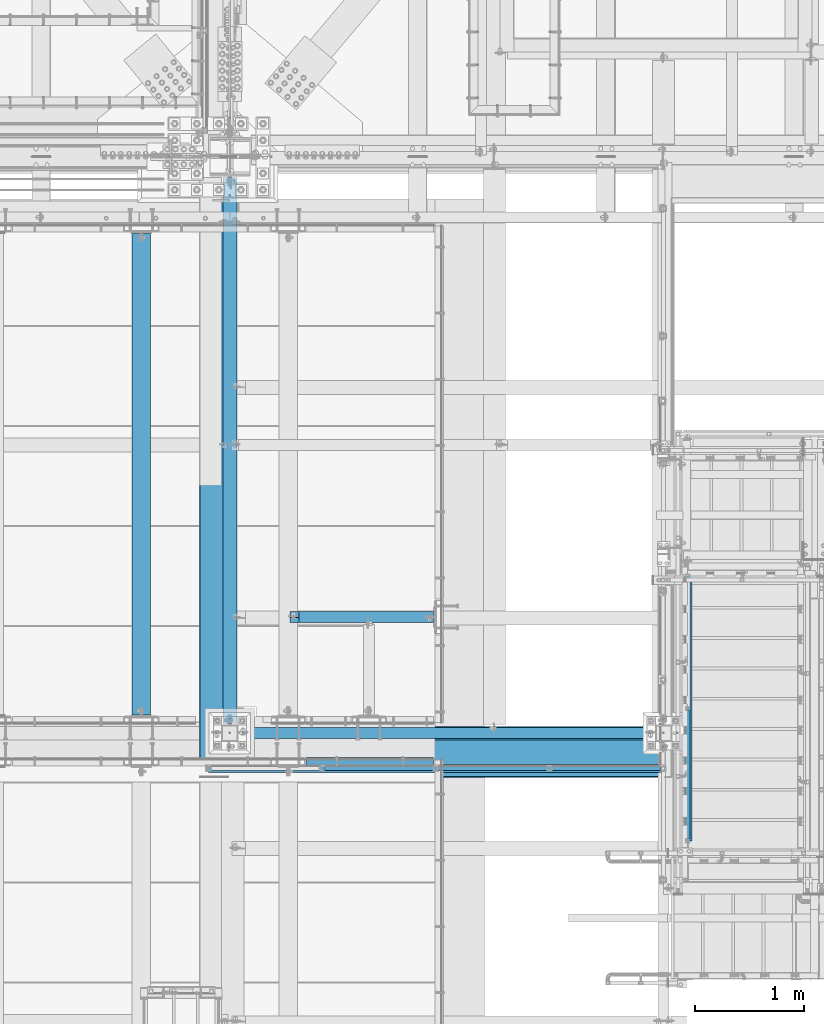
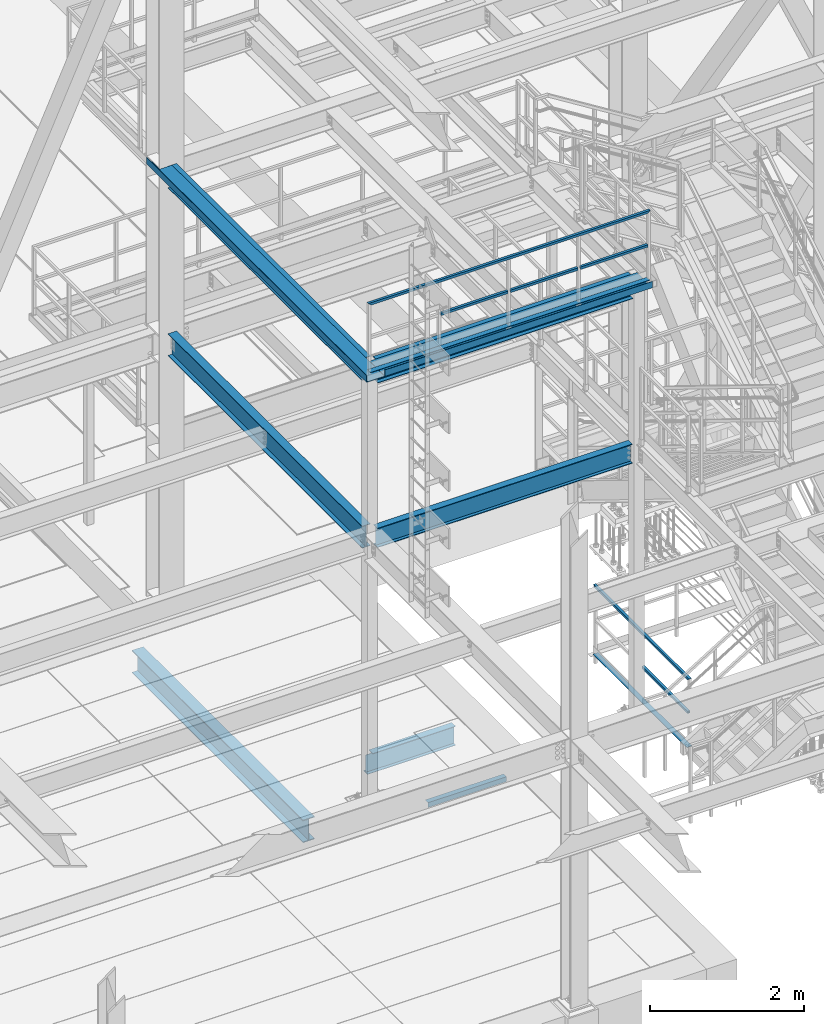
# One storey, part 1757 of 3843: 17 beams, 11 elements without a shape of their own.
"""IFC2X3 building model written with IfcOpenShell, lengths in millimetres."""

import ifcopenshell
import ifcopenshell.guid

model = None  # the IFC model being written
_history = None  # IfcOwnerHistory: only IFC2X3 demands one
_inside = {}  # id of a spatial element -> (the spatial element, [elements in it])
_under = {}  # id of a project, library or spatial element -> (it, [spatial elements below it])
_declared = {}  # id of a project -> (the project, [libraries it declares])
_typed = {}  # id of a type object -> (the type object, [elements of that type])
_made_of = {}  # id of a material, layer set ... -> (it, [elements and type objects made of it])


def new_model(schema):
    """Start an empty IFC model of exactly this schema.

    Asked for "IFC4X3", IfcOpenShell would pick the latest addendum, in which some entities
    have other attributes; the version numbers below select the first issue.
    IFC2X3 requires an IfcOwnerHistory on every rooted entity: one is made here for all.
    """
    global model, _history
    if schema == "IFC4X3":
        model = ifcopenshell.file(schema_version=(4, 3, 0, 0))
    else:
        model = ifcopenshell.file(schema=schema)
    _inside.clear()
    _under.clear()
    _declared.clear()
    _typed.clear()
    _made_of.clear()
    _history = None
    if model.schema == "IFC2X3":
        org = make("IfcOrganization", Name="unknown")
        user = make(
            "IfcPersonAndOrganization",
            ThePerson=make("IfcPerson", FamilyName="unknown"),
            TheOrganization=org,
        )
        app = make(
            "IfcApplication",
            ApplicationDeveloper=org,
            Version="unknown",
            ApplicationFullName="unknown",
            ApplicationIdentifier="unknown",
        )
        _history = make(
            "IfcOwnerHistory",
            OwningUser=user,
            OwningApplication=app,
            ChangeAction="ADDED",
            CreationDate=0,
        )
    return model


def make(cls, **values):
    """One entity of the class cls with the attributes given. An attribute that is None is left unset."""
    return model.create_entity(
        cls, **{name: value for name, value in values.items() if value is not None}
    )


def rooted(cls, **values):
    """An entity with a GlobalId (a new one), such as an element, a storey or a relation."""
    return make(cls, GlobalId=ifcopenshell.guid.new(), OwnerHistory=_history, **values)


def si_unit(unit_type, name, prefix=None):
    """IfcSIUnit, for example si_unit("LENGTHUNIT", "METRE", prefix="MILLI")."""
    return make("IfcSIUnit", UnitType=unit_type, Prefix=prefix, Name=name)


def assignment(units):
    """IfcUnitAssignment: the units of a project."""
    return None if units is None else make("IfcUnitAssignment", Units=units)


def point(xyz):
    """IfcCartesianPoint."""
    return None if xyz is None else make("IfcCartesianPoint", Coordinates=xyz)


def direction(xyz):
    """IfcDirection."""
    return None if xyz is None else make("IfcDirection", DirectionRatios=xyz)


def frame(location, z_axis=None, x_axis=None):
    """IfcAxis2Placement3D, a coordinate frame: its origin and axes. An axis left out is left unset."""
    return make(
        "IfcAxis2Placement3D",
        Location=point(location),
        Axis=direction(z_axis),
        RefDirection=direction(x_axis),
    )


def origin_with_axes():
    """The frame at (0, 0, 0) with the z axis (0, 0, 1) and the x axis (1, 0, 0) written out."""
    return frame((0.0, 0.0, 0.0), z_axis=(0.0, 0.0, 1.0), x_axis=(1.0, 0.0, 0.0))


def place(relative_to, where):
    """IfcLocalPlacement: puts the frame where relative to a parent placement (None: the world)."""
    return make(
        "IfcLocalPlacement", PlacementRelTo=relative_to, RelativePlacement=where
    )


def context(
    kind, dimensions, precision=None, world=None, true_north=None, identifier=None
):
    """IfcGeometricRepresentationContext, for example the 3D "Model" context."""
    return make(
        "IfcGeometricRepresentationContext",
        ContextIdentifier=identifier,
        ContextType=kind,
        CoordinateSpaceDimension=dimensions,
        Precision=precision,
        WorldCoordinateSystem=world,
        TrueNorth=true_north,
    )


def subcontext(parent, identifier, kind, view, scale=None):
    """IfcGeometricRepresentationSubContext, for example "Body" below "Model"."""
    return make(
        "IfcGeometricRepresentationSubContext",
        ContextIdentifier=identifier,
        ContextType=kind,
        ParentContext=parent,
        TargetScale=scale,
        TargetView=view,
    )


def project(units=None, contexts=None):
    """IfcProject with its units and contexts."""
    return rooted(
        "IfcProject",
        Name="project",
        RepresentationContexts=contexts,
        UnitsInContext=assignment(units),
    )


def spatial(cls, under=None, at=None, **own):
    """A site, building, storey or space (cls), placed at a placement, below another one or the project."""
    s = rooted(cls, ObjectPlacement=at, **own)
    if under is not None:
        _under.setdefault(under.id(), (under, []))[1].append(s)
    return s


def faces_of(points, faces, orient=None, outer=None):
    """IfcFace entities. A face is a list of loops; a loop is a list of indices into points, from 0.

    orient and outer hold one flag for each loop. By default every Orientation is true, the
    first loop of a face is its IfcFaceOuterBound and the others are IfcFaceBound.
    """
    made = []
    for i, loops in enumerate(faces):
        bounds = []
        for j, loop in enumerate(loops):
            is_outer = j == 0 if outer is None else outer[i][j]
            bounds.append(
                make(
                    "IfcFaceOuterBound" if is_outer else "IfcFaceBound",
                    Bound=make("IfcPolyLoop", Polygon=[points[k] for k in loop]),
                    Orientation=True if orient is None else orient[i][j],
                )
            )
        made.append(make("IfcFace", Bounds=bounds))
    return made


def faceted_brep(points, faces, orient=None, outer=None, voids=None):
    """IfcFacetedBrep: a solid bounded by flat faces; with voids (closed shells), ...WithVoids."""
    shared = [point(p) for p in points]
    hull = make("IfcClosedShell", CfsFaces=faces_of(shared, faces, orient, outer))
    if voids is None:
        return make("IfcFacetedBrep", Outer=hull)
    return make(
        "IfcFacetedBrepWithVoids",
        Outer=hull,
        Voids=[
            make(cls, CfsFaces=faces_of(shared, fs, o, b)) for cls, fs, o, b in voids
        ],
    )


def shape(context_of_items, identifier, shape_type, items):
    """IfcShapeRepresentation: the items that make up one representation, for example the "Body"."""
    return make(
        "IfcShapeRepresentation",
        ContextOfItems=context_of_items,
        RepresentationIdentifier=identifier,
        RepresentationType=shape_type,
        Items=items,
    )


def material(Name=None, Category=None):
    """IfcMaterial."""
    return make("IfcMaterial", Name=Name, Category=Category)


def made_of(thing, what):
    """Note that an element or type object is made of a material, layer set ...; save() writes the relation."""
    if what is not None:
        _made_of.setdefault(what.id(), (what, []))[1].append(thing)
    return thing


def type_object(cls, material=None, **own):
    """A type object (cls), such as IfcWallType, which elements share."""
    return made_of(rooted(cls, **own), material)


def element(
    cls,
    number,
    at=None,
    inside=None,
    cuts=None,
    type_object=None,
    material=None,
    context=None,
    identifier="Body",
    shape_type=None,
    held_by="IfcProductDefinitionShape",
    body=None,
    shapes=None,
    **own,
):
    """One element of the class cls, such as IfcWall. Its Tag is "e" and its number.

    at: its placement. inside: the storey or other place that contains it. cuts: it is an
    opening in that element (IfcRelVoidsElement). A single representation is given by context,
    identifier, shape_type and body (its items); several are given by shapes. held_by: the class
    of the entity that holds the representations. save() writes the other relations.
    """
    e = rooted(cls, Tag="e%d" % number, ObjectPlacement=at, **own)
    if body is not None:
        shapes = [shape(context, identifier, shape_type, body)]
    if shapes is not None:
        e.Representation = make(held_by, Representations=shapes)
    if inside is not None:
        _inside.setdefault(inside.id(), (inside, []))[1].append(e)
    if cuts is not None:
        rooted(
            "IfcRelVoidsElement", RelatingBuildingElement=cuts, RelatedOpeningElement=e
        )
    if type_object is not None:
        _typed.setdefault(type_object.id(), (type_object, []))[1].append(e)
    return made_of(e, material)


def aggregate(whole, parts):
    """IfcRelAggregates: a whole, such as a stair, and the parts it consists of."""
    return rooted("IfcRelAggregates", RelatingObject=whole, RelatedObjects=parts)


def save(model, path):
    """Write the relations noted so far, then the file.

    IfcRelAggregates (storeys below a building ...), IfcRelContainedInSpatialStructure (elements
    in a storey), IfcRelDefinesByType, IfcRelAssociatesMaterial and IfcRelDeclares: one each for
    every whole, place, type object, material and project.
    """
    for whole, parts in _under.values():
        aggregate(whole, parts)
    for where, things in _inside.values():
        rooted(
            "IfcRelContainedInSpatialStructure",
            RelatedElements=things,
            RelatingStructure=where,
        )
    for kind, things in _typed.values():
        rooted("IfcRelDefinesByType", RelatedObjects=things, RelatingType=kind)
    for what, things in _made_of.values():
        rooted("IfcRelAssociatesMaterial", RelatedObjects=things, RelatingMaterial=what)
    for by, libraries in _declared.values():
        rooted("IfcRelDeclares", RelatingContext=by, RelatedDefinitions=libraries)
    model.write(path)


model = new_model("IFC2X3")

# Units and contexts
model_context = context("Model", 3, precision=1e-05, world=origin_with_axes())
body_context = subcontext(model_context, "Body", "Model", "MODEL_VIEW")
ifc_project = project(units=[si_unit("LENGTHUNIT", "METRE", prefix="MILLI"), si_unit("AREAUNIT", "SQUARE_METRE"), si_unit("VOLUMEUNIT", "CUBIC_METRE"), si_unit("MASSUNIT", "GRAM", prefix="KILO"), si_unit("TIMEUNIT", "SECOND"), si_unit("PLANEANGLEUNIT", "RADIAN"), si_unit("SOLIDANGLEUNIT", "STERADIAN"), si_unit("THERMODYNAMICTEMPERATUREUNIT", "DEGREE_CELSIUS"), si_unit("LUMINOUSINTENSITYUNIT", "LUMEN")], contexts=[model_context])

# Site, building, storey
site_placement = place(None, origin_with_axes())
site = spatial("IfcSite", under=ifc_project, at=site_placement, CompositionType="ELEMENT")
building_placement = place(site_placement, origin_with_axes())
building = spatial("IfcBuilding", under=site, at=building_placement, Name="Undefined", CompositionType="ELEMENT")
storey_placement = place(building_placement, origin_with_axes())
storey = spatial("IfcBuildingStorey", under=building, at=storey_placement, Name="Undefined", CompositionType="ELEMENT", Elevation=0.0)

# Assembly, beams
assembly_1_placement = place(storey_placement, origin_with_axes())
assembly_1 = element("IfcElementAssembly", 1, at=assembly_1_placement, inside=storey, Name="RAIL", AssemblyPlace="NOTDEFINED", PredefinedType="RIGID_FRAME")
ifc_material_1 = material()
beam_type_1 = type_object("IfcBeamType", Name="HSS1-1/2X1-1/2X1/4", PredefinedType="NOTDEFINED")
beam_1_placement = place(assembly_1_placement, frame((51938.2374968993, 19983.4499877939, 38099.9999983618), z_axis=(0.0, 0.0, 1.0), x_axis=(1.0, 0.0, 0.0)))
beam_1 = element("IfcBeam", 2, at=beam_1_placement, type_object=beam_type_1, material=ifc_material_1, Name="RAIL", ObjectType="HSS1-1/2X1-1/2X1/4", context=body_context, shape_type="Brep", body=[
    faceted_brep([(1027.11250303521, -19.0500000007705, 19.0499992350015), (1027.11250303521, -19.0499992350015, -19.0499992350015), (1027.11250303521, 19.0499992350015, -19.0499992350015), (1027.11250303521, 19.0499992350015, 19.0499992350015), (1027.11250303521, -12.6999993300014, 12.6999993299978), (1027.11250303521, 12.6999993300014, 12.6999993299978), (1027.11250303521, 12.6999993300014, -12.6999993299978), (1027.11250303521, -12.6999993300014, -12.6999993299978), (19.0499992350015, 19.0499992350015, -19.0499992350015), (19.0499992350015, 19.0499992350015, 19.0499992350015), (19.0499992350015, -19.0499992350015, 19.0499992350015), (19.0499992350015, -19.0499992350015, -19.0499992350015), (19.0499992350015, 12.6999993299978, 12.6999993299978), (19.0499992350015, -12.6999993299978, 12.6999993299978), (19.0499992350015, -12.6999993299978, -12.6999993299978), (19.0499992350015, 12.6999993299978, -12.6999993299978)], [[[0, 1, 2, 3], [4, 5, 6, 7]], [[8, 9, 3, 2]], [[9, 10, 0, 3]], [[10, 11, 1, 0]], [[11, 8, 2, 1]], [[11, 10, 9, 8], [12, 13, 14, 15]], [[14, 13, 4, 7]], [[15, 14, 7, 6]], [[12, 15, 6, 5]], [[13, 12, 5, 4]]]),
])
beam_2_placement = place(assembly_1_placement, frame((50892.0749938638, 19983.4499877937, 38099.9999983618), z_axis=(0.0, 0.0, 1.0), x_axis=(1.0, 0.0, 0.0)))
beam_2 = element("IfcBeam", 3, at=beam_2_placement, type_object=beam_type_1, material=ifc_material_1, Name="RAIL", ObjectType="HSS1-1/2X1-1/2X1/4", context=body_context, shape_type="Brep", body=[
    faceted_brep([(1027.11250303521, -19.0500000007705, 19.0499992350015), (1027.11250303521, -19.0499992350015, -19.0499992350015), (1027.11250303521, 19.0499992350015, -19.0499992350015), (1027.11250303521, 19.0499992350015, 19.0499992350015), (1027.11250303521, -12.6999993300014, 12.6999993299978), (1027.11250303521, 12.6999993300014, 12.6999993299978), (1027.11250303521, 12.6999993300014, -12.6999993299978), (1027.11250303521, -12.6999993300014, -12.6999993299978), (19.0499992350015, 19.0499992350015, -19.0499992350015), (19.0499992350015, 19.0499992350015, 19.0499992350015), (19.0499992350015, -19.0499992350015, 19.0499992350015), (19.0499992350015, -19.0499992350015, -19.0499992350015), (19.0499992350015, 12.6999993299978, 12.6999993299978), (19.0499992350015, -12.6999993299978, 12.6999993299978), (19.0499992350015, -12.6999993299978, -12.6999993299978), (19.0499992350015, 12.6999993299978, -12.6999993299978)], [[[0, 1, 2, 3], [4, 5, 6, 7]], [[8, 9, 3, 2]], [[9, 10, 0, 3]], [[10, 11, 1, 0]], [[11, 8, 2, 1]], [[11, 10, 9, 8], [12, 13, 14, 15]], [[14, 13, 4, 7]], [[15, 14, 7, 6]], [[12, 15, 6, 5]], [[13, 12, 5, 4]]]),
])
beam_3_placement = place(assembly_1_placement, frame((49845.9124908286, 19983.4499877939, 38099.9999983618), z_axis=(0.0, 0.0, 1.0), x_axis=(1.0, 0.0, 0.0)))
beam_3 = element("IfcBeam", 4, at=beam_3_placement, type_object=beam_type_1, material=ifc_material_1, Name="RAIL", ObjectType="HSS1-1/2X1-1/2X1/4", context=body_context, shape_type="Brep", body=[
    faceted_brep([(1027.11250303521, -19.0500000007705, 19.0499992350015), (1027.11250303521, -19.0499992350015, -19.0499992350015), (1027.11250303521, 19.0499992350015, -19.0499992350015), (1027.11250303521, 19.0499992350015, 19.0499992350015), (1027.11250303521, -12.6999993300014, 12.6999993299978), (1027.11250303521, 12.6999993300014, 12.6999993299978), (1027.11250303521, 12.6999993300014, -12.6999993299978), (1027.11250303521, -12.6999993300014, -12.6999993299978), (19.0499992350015, 19.0499992350015, -19.0499992350015), (19.0499992350015, 19.0499992350015, 19.0499992350015), (19.0499992350015, -19.0499992350015, 19.0499992350015), (19.0499992350015, -19.0499992350015, -19.0499992350015), (19.0499992350015, 12.6999993299978, 12.6999993299978), (19.0499992350015, -12.6999993299978, 12.6999993299978), (19.0499992350015, -12.6999993299978, -12.6999993299978), (19.0499992350015, 12.6999993299978, -12.6999993299978)], [[[0, 1, 2, 3], [4, 5, 6, 7]], [[8, 9, 3, 2]], [[9, 10, 0, 3]], [[10, 11, 1, 0]], [[11, 8, 2, 1]], [[11, 10, 9, 8], [12, 13, 14, 15]], [[14, 13, 4, 7]], [[15, 14, 7, 6]], [[12, 15, 6, 5]], [[13, 12, 5, 4]]]),
])
beam_4_placement = place(assembly_1_placement, frame((53003.4499991695, 19983.4499877938, 38633.3999983618), z_axis=(0.0, 0.0, -1.0), x_axis=(-1.0, 0.0, 0.0)))
beam_4 = element("IfcBeam", 5, at=beam_4_placement, type_object=beam_type_1, material=ifc_material_1, Name="RAIL", ObjectType="HSS1-1/2X1-1/2X1/4", context=body_context, shape_type="Brep", body=[
    faceted_brep([(6.34999999999854, 12.6999993299978, -12.6999993299978), (6.34999999999854, -12.6999993299978, -12.6999993299978), (4216.40001070656, -12.6999993300014, -12.6999993299978), (4216.40001070656, 12.6999993300014, -12.6999993299978), (31.7500007135677, -12.6999993300014, 12.6999993299978), (4191.00001204656, -12.6999993300014, 12.6999993299978), (31.7500007135677, 12.6999993300014, 12.6999993299978), (4191.00001204656, 12.6999993300014, 12.6999993299978), (0.0, 19.0500000000029, -19.0499999999993), (38.0999984699883, 19.0499992350015, 19.0499992350015), (4184.65001214156, 19.0499992350015, 19.0499992350015), (4222.75001061156, 19.0499992350015, -19.0499992350015), (38.0999984699883, -19.0499992350015, 19.0499992350015), (4184.65001214156, -19.0499992350015, 19.0499992350015), (0.0, -19.0499992350015, -19.0499992350015), (4222.75001061156, -19.0499992350015, -19.0499992350015)], [[[0, 1, 2, 3]], [[1, 4, 5, 2]], [[4, 6, 7, 5]], [[6, 0, 3, 7]], [[8, 9, 10, 11]], [[9, 12, 13, 10]], [[12, 14, 15, 13]], [[14, 8, 11, 15]], [[13, 15, 11, 10], [5, 7, 3, 2]], [[14, 12, 9, 8], [6, 4, 1, 0]]]),
])
aggregate(assembly_1, [beam_1, beam_2, beam_3, beam_4])

assembly_2_placement = place(storey_placement, origin_with_axes())
assembly_2 = element("IfcElementAssembly", 6, at=assembly_2_placement, inside=storey, Name="RAIL", AssemblyPlace="NOTDEFINED", PredefinedType="RIGID_FRAME")
beam_5_placement = place(assembly_2_placement, frame((53212.9999992346, 19316.6999992958, 31013.3999999994), z_axis=(0.0, 0.0, 1.0), x_axis=(0.0, 1.0, 0.0)))
beam_5 = element("IfcBeam", 7, at=beam_5_placement, type_object=beam_type_1, material=ifc_material_1, Name="RAIL", ObjectType="HSS1-1/2X1-1/2X1/4", context=body_context, shape_type="Brep", body=[
    faceted_brep([(1200.15000153688, -19.0499992350015, 19.0499992350015), (1200.15000153688, -19.0499992350015, -19.0499992350015), (1200.15000153688, 19.0499992350015, -19.0499992350015), (1200.15000153688, 19.0499992350015, 19.0499992350015), (1200.15000153688, -12.6999993299978, 12.6999993299978), (1200.15000153688, 12.6999993299978, 12.6999993299978), (1200.15000153688, 12.6999993299978, -12.6999993299978), (1200.15000153688, -12.6999993299978, -12.6999993299978), (19.0499992350015, 19.0499992350015, -19.0499992350015), (19.0499992350015, 19.0499992350015, 19.0499992350015), (19.0499992350015, -19.0499992350015, 19.0499992350015), (19.0499992350015, -19.0499992350015, -19.0499992350015), (19.0499992350015, 12.6999993299978, 12.6999993299978), (19.0499992350015, -12.6999993299978, 12.6999993299978), (19.0499992350015, -12.6999993299978, -12.6999993299978), (19.0499992350015, 12.6999993299978, -12.6999993299978)], [[[0, 1, 2, 3], [4, 5, 6, 7]], [[8, 9, 3, 2]], [[9, 10, 0, 3]], [[10, 11, 1, 0]], [[11, 8, 2, 1]], [[11, 10, 9, 8], [12, 13, 14, 15]], [[14, 13, 4, 7]], [[15, 14, 7, 6]], [[12, 15, 6, 5]], [[13, 12, 5, 4]]]),
])
beam_6_placement = place(assembly_2_placement, frame((53212.999999235, 21774.1499992224, 31546.8), z_axis=(0.0, 0.0, -1.0), x_axis=(0.0, -1.0, 0.0)))
beam_6 = element("IfcBeam", 8, at=beam_6_placement, type_object=beam_type_1, material=ifc_material_1, Name="RAIL", ObjectType="HSS1-1/2X1-1/2X1/4", context=body_context, shape_type="Brep", body=[
    faceted_brep([(6.34999999999854, 12.6999993299978, -12.6999993299978), (6.34999999999854, -12.6999993299978, -12.6999993299978), (2470.14999925665, -12.6999993299978, -12.6999993300014), (2470.14999925665, 12.6999993299978, -12.6999993300014), (31.7500007135677, -12.6999993300014, 12.6999993299978), (2444.75000059665, -12.6999993299978, 12.6999993300014), (31.7500007135677, 12.6999993300014, 12.6999993299978), (2444.75000059665, 12.6999993299978, 12.6999993300014), (0.0, 19.0500000000029, -19.0499999999993), (38.0999984699883, 19.0499992350015, 19.0499992350015), (2438.40000069165, 19.0499992350015, 19.0499992350015), (2476.49999916165, 19.0499992350015, -19.0499992350015), (38.0999984699883, -19.0499992350015, 19.0499992350015), (2438.40000069165, -19.0499992350015, 19.0499992350015), (0.0, -19.0499992350015, -19.0499992350015), (2476.49999916165, -19.0499992350015, -19.0499992350015)], [[[0, 1, 2, 3]], [[1, 4, 5, 2]], [[4, 6, 7, 5]], [[6, 0, 3, 7]], [[8, 9, 10, 11]], [[9, 12, 13, 10]], [[12, 14, 15, 13]], [[14, 8, 11, 15]], [[13, 15, 11, 10], [5, 7, 3, 2]], [[14, 12, 9, 8], [6, 4, 1, 0]]]),
])
aggregate(assembly_2, [beam_5, beam_6])

# Assembly, beam
assembly_3_placement = place(storey_placement, origin_with_axes())
assembly_3 = element("IfcElementAssembly", 9, at=assembly_3_placement, inside=storey, Name="ref.", AssemblyPlace="NOTDEFINED", PredefinedType="RIGID_FRAME")
ifc_material_2 = material(Name="STEEL/Steel_Undefined")
beam_type_2 = type_object("IfcBeamType", PredefinedType="NOTDEFINED")
beam_7_placement = place(assembly_3_placement, frame((48799.749987793, 19983.449987793, 37563.4249983618), z_axis=(0.0, 1.0, 0.0), x_axis=(1.0, 0.0, 0.0)))
beam_7 = element("IfcBeam", 10, at=beam_7_placement, type_object=beam_type_2, material=ifc_material_2, Name="ref.", context=body_context, shape_type="Brep", body=[
    faceted_brep([(0.0, 3.17500000000291, -38.0999999999985), (0.0, 3.17500000000291, 38.0999999999985), (4184.65001214144, 3.17500000000291, 38.0999999999985), (4184.65001214144, 3.17500000000291, -38.0999999999985), (0.0, -3.17500000000291, 38.0999999999985), (4184.65001214144, -3.17500000000291, 38.0999999999985), (0.0, -3.17500000000291, -38.0999999999985), (4184.65001214144, -3.17500000000291, -38.0999999999985)], [[[0, 1, 2, 3]], [[1, 4, 5, 2]], [[4, 6, 7, 5]], [[6, 0, 3, 7]], [[5, 7, 3, 2]], [[6, 4, 1, 0]]]),
])
aggregate(assembly_3, [beam_7])

assembly_4_placement = place(storey_placement, origin_with_axes())
assembly_4 = element("IfcElementAssembly", 11, at=assembly_4_placement, inside=storey, Name="ref.", AssemblyPlace="NOTDEFINED", PredefinedType="RIGID_FRAME")
beam_8_placement = place(assembly_4_placement, frame((53212.999999235, 21755.0999999874, 30476.825), z_axis=(1.0, 0.0, 0.0), x_axis=(0.0, -1.0, 0.0)))
beam_8 = element("IfcBeam", 12, at=beam_8_placement, type_object=beam_type_2, material=ifc_material_2, Name="ref.", context=body_context, shape_type="Brep", body=[
    faceted_brep([(0.0, 3.17500000000291, -38.0999999999985), (0.0, 3.17500000000291, 38.0999999999985), (2438.40000069164, 3.17499999999927, 38.0999999999985), (2438.40000069164, 3.17499999999927, -38.0999999999985), (0.0, -3.17500000000291, 38.0999999999985), (2438.40000069164, -3.17499999999927, 38.0999999999985), (0.0, -3.17500000000291, -38.0999999999985), (2438.40000069164, -3.17499999999927, -38.0999999999985)], [[[0, 1, 2, 3]], [[1, 4, 5, 2]], [[4, 6, 7, 5]], [[6, 0, 3, 7]], [[5, 7, 3, 2]], [[6, 4, 1, 0]]]),
])
aggregate(assembly_4, [beam_8])

assembly_5_placement = place(storey_placement, origin_with_axes())
assembly_5 = element("IfcElementAssembly", 13, at=assembly_5_placement, inside=storey, Name="ANGLE", AssemblyPlace="NOTDEFINED", PredefinedType="RIGID_FRAME")
ifc_material_3 = material(Name="STEEL/A36")
beam_type_3 = type_object("IfcBeamType", Name="L3X3X1/4", PredefinedType="NOTDEFINED")
beam_9_placement = place(assembly_5_placement, frame((49698.274279864, 20043.7750027871, 30365.7000030518), z_axis=(0.0, 0.0, -1.0), x_axis=(1.0, 0.0, 0.0)))
beam_9 = element("IfcBeam", 14, at=beam_9_placement, type_object=beam_type_3, material=ifc_material_3, Name="ANGLE", ObjectType="L3X3X1/4", context=body_context, shape_type="Brep", body=[
    faceted_brep([(0.0, 38.0999999999985, -38.0999999999985), (0.0, 38.0999999999985, 38.0999999999985), (1174.75072021487, 38.1000000000004, 38.0999999999985), (1174.75072021487, 38.1000000000004, -38.0999999999985), (0.0, 31.75, 38.0999999999985), (1174.75072021487, 31.75, 38.0999999999985), (0.0, 31.75, -31.75), (1174.75072021487, 31.75, -31.75), (0.0, -38.0999999999985, -31.75), (1174.75072021487, -38.1000000000004, -31.75), (0.0, -38.0999999999985, -38.0999999999985), (1174.75072021487, -38.1000000000004, -38.0999999999985)], [[[0, 1, 2, 3]], [[1, 4, 5, 2]], [[4, 6, 7, 5]], [[6, 8, 9, 7]], [[8, 10, 11, 9]], [[10, 0, 3, 11]], [[5, 7, 9, 11, 3, 2]], [[10, 8, 6, 4, 1, 0]]]),
])
aggregate(assembly_5, [beam_9])

assembly_6_placement = place(storey_placement, origin_with_axes())
assembly_6 = element("IfcElementAssembly", 15, at=assembly_6_placement, inside=storey, Name="BEAM", AssemblyPlace="NOTDEFINED", PredefinedType="RIGID_FRAME")
ifc_material_4 = material(Name="STEEL/A992")
beam_type_4 = type_object("IfcBeamType", Name="W12X19", PredefinedType="NOTDEFINED")
beam_10_placement = place(assembly_6_placement, frame((48996.6, 20307.3, 34656.7125), z_axis=(0.0, 0.0, 1.0), x_axis=(1.0, 0.0, 0.0)))
beam_10 = element("IfcBeam", 16, at=beam_10_placement, type_object=beam_type_4, material=ifc_material_4, Name="BEAM", ObjectType="W12X19", context=body_context, shape_type="Brep", body=[
    faceted_brep([(88.8999999999942, -50.7999999999993, -153.987500000003), (88.8999999999942, 50.7999999999993, -153.987500000003), (3905.25000000001, 50.7999999999993, -153.987500000003), (3905.25000000001, -50.7999999999993, -153.987500000003), (88.8999999999942, -50.7999999999993, -144.462500000001), (88.8999999999942, -3.17499999999927, -144.462500000001), (88.8999999999942, -3.17499999999927, 144.462500000001), (88.8999999999942, -50.7999999999993, 144.462500000001), (88.8999999999942, -50.7999999999993, 153.987500000003), (88.8999999999942, 50.7999999999993, 153.987500000003), (88.8999999999942, 50.7999999999993, 144.462500000001), (88.8999999999942, 3.17499999999927, 144.462500000001), (88.8999999999942, 3.17499999999927, -144.462500000001), (88.8999999999942, 50.7999999999993, -144.462500000001), (3905.25000000001, -50.7999999999993, -144.462500000001), (3905.25000000001, -3.17499999999927, -144.462500000001), (3905.25000000001, -3.17499999999927, 144.462500000001), (3905.25000000001, -50.7999999999993, 144.462500000001), (3905.25000000001, -50.7999999999993, 153.987500000003), (3905.25000000001, 50.7999999999993, 153.987500000003), (3905.25000000001, 50.7999999999993, 144.462500000001), (3905.25000000001, 3.17499999999927, 144.462500000001), (3905.25000000001, 3.17499999999927, -144.462500000001), (3905.25000000001, 50.7999999999993, -144.462500000001)], [[[0, 1, 2, 3]], [[0, 4, 5, 6, 7, 8, 9, 10, 11, 12, 13, 1]], [[5, 4, 14, 15]], [[6, 5, 15, 16]], [[7, 6, 16, 17]], [[8, 7, 17, 18]], [[9, 8, 18, 19]], [[10, 9, 19, 20]], [[11, 10, 20, 21]], [[12, 11, 21, 22]], [[13, 12, 22, 23]], [[1, 13, 23, 2]], [[22, 21, 20, 19, 18, 17, 16, 15, 14, 3, 2, 23]], [[4, 0, 3, 14]]]),
])
aggregate(assembly_6, [beam_10])

assembly_7_placement = place(storey_placement, origin_with_axes())
assembly_7 = element("IfcElementAssembly", 17, at=assembly_7_placement, inside=storey, Name="BEAM", AssemblyPlace="NOTDEFINED", PredefinedType="RIGID_FRAME")
beam_type_5 = type_object("IfcBeamType", PredefinedType="NOTDEFINED")
beam_11_placement = place(assembly_7_placement, frame((48983.9, 22756.927, 37468.175), z_axis=(0.0, -1.0, 0.0), x_axis=(-1.0, 0.0, 0.0)))
beam_11 = element("IfcBeam", 18, at=beam_11_placement, type_object=beam_type_5, material=ifc_material_3, Name="BENT_PLATE", context=body_context, shape_type="Brep", body=[
    faceted_brep([(184.150000000001, -3.17500000000291, -2655.773), (184.150000000001, 3.17500000000291, -2655.773), (184.149999999994, 3.17500000000291, -2856.027), (184.149999999994, -3.17500000000291, -2856.027), (0.0, -3.17500000000291, -2655.77299999999), (0.0, 3.17500000000291, -2655.77299999999), (266.700012207031, 3.17500000000291, 2856.027), (0.0, 3.17500000000291, 2856.027), (0.0, -3.17500000000291, 2856.027), (260.350012207025, -3.17500000000291, 2856.027), (260.350012207025, -98.4249984741182, 2856.027), (266.700012207031, -98.4249984741182, 2856.027), (266.700012207031, 3.17500000000291, -2856.027), (266.700012207031, -98.4249984741182, -2856.027), (260.350012207025, -98.4249984741182, -2856.027), (260.350012207025, -3.17500000000291, -2856.027)], [[[0, 1, 2, 3]], [[4, 5, 1, 0]], [[6, 7, 8, 9, 10, 11]], [[12, 6, 11, 13]], [[10, 14, 13, 11]], [[9, 15, 14, 10]], [[12, 13, 14, 15, 3, 2]], [[7, 6, 12, 2, 1, 5]], [[8, 7, 5, 4]], [[15, 9, 8, 4, 0, 3]]]),
])

# Assembly, beams
assembly_8_placement = place(storey_placement, origin_with_axes())
assembly_8 = element("IfcElementAssembly", 19, at=assembly_8_placement, inside=storey, Name="BEAM", AssemblyPlace="NOTDEFINED", PredefinedType="RIGID_FRAME")
beam_type_6 = type_object("IfcBeamType", PredefinedType="NOTDEFINED")
beam_12_placement = place(assembly_8_placement, frame((50993.675, 20294.6, 37468.175), z_axis=(-1.0, 0.0, 0.0), x_axis=(0.0, -1.0, 0.0)))
beam_12 = element("IfcBeam", 20, at=beam_12_placement, type_object=beam_type_6, material=ifc_material_3, Name="BENT_PLATE", context=body_context, shape_type="Brep", body=[
    faceted_brep([(0.0, -3.17500000000291, -2003.425), (0.0, -3.17500000000291, 2003.425), (0.0, 3.17500000000291, 2003.425), (0.0, 3.17500000000291, -2003.425), (387.350012207029, 3.17500000000291, 2003.425), (387.350012207029, 3.17500000000291, -2003.425), (393.700012207028, -3.17500000000291, -2003.425), (393.700012207028, -3.17500000000291, 2003.425), (387.350012207029, 98.4249984741182, 2003.425), (387.350012207029, 98.4249984741182, -2003.425), (393.700012207028, 98.4249984741182, 2003.425), (393.700012207028, 98.4249984741182, -2003.425)], [[[0, 1, 2, 3]], [[3, 2, 4, 5]], [[1, 0, 6, 7]], [[5, 4, 8, 9]], [[4, 2, 1, 7, 10, 8]], [[7, 6, 11, 10]], [[6, 0, 3, 5, 9, 11]], [[10, 11, 9, 8]]]),
])
beam_type_7 = type_object("IfcBeamType", Name="W14X22", PredefinedType="NOTDEFINED")
beam_13_placement = place(assembly_8_placement, frame((48996.6, 20307.3, 37290.375), z_axis=(0.0, 0.0, 1.0), x_axis=(1.0, 0.0, 0.0)))
beam_13 = element("IfcBeam", 21, at=beam_13_placement, type_object=beam_type_7, material=ifc_material_4, Name="BEAM", ObjectType="W14X22", context=body_context, shape_type="Brep", body=[
    faceted_brep([(88.9000000000087, -63.5, -174.625), (88.9000000000087, 63.5, -174.625), (3905.25000000001, 63.5, -174.625), (3905.25000000001, -63.5, -174.625), (88.9000000000087, -63.5, -166.6875), (88.9000000000087, -3.17499999999927, -166.6875), (88.9000000000087, -3.17499999999927, 166.6875), (88.9000000000087, -63.5, 166.6875), (88.9000000000087, -63.5, 174.625), (88.9000000000087, 63.5, 174.625), (88.9000000000087, 63.5, 166.6875), (88.9000000000087, 3.17499999999927, 166.6875), (88.9000000000087, 3.17499999999927, -166.6875), (88.9000000000087, 63.5, -166.6875), (3905.25000000001, -63.5, -166.6875), (3905.25000000001, -3.17499999999927, -166.6875), (3905.25000000001, -3.17499999999927, 166.6875), (3905.25000000001, -63.5, 166.6875), (3905.25000000001, -63.5, 174.625), (3905.25000000001, 63.5, 174.625), (3905.25000000001, 63.5, 166.6875), (3905.25000000001, 3.17499999999927, 166.6875), (3905.25000000001, 3.17499999999927, -166.6875), (3905.25000000001, 63.5, -166.6875)], [[[0, 1, 2, 3]], [[0, 4, 5, 6, 7, 8, 9, 10, 11, 12, 13, 1]], [[5, 4, 14, 15]], [[6, 5, 15, 16]], [[7, 6, 16, 17]], [[8, 7, 17, 18]], [[9, 8, 18, 19]], [[10, 9, 19, 20]], [[11, 10, 20, 21]], [[12, 11, 21, 22]], [[13, 12, 22, 23]], [[1, 13, 23, 2]], [[22, 21, 20, 19, 18, 17, 16, 15, 14, 3, 2, 23]], [[4, 0, 3, 14]]]),
])
aggregate(assembly_8, [beam_12, beam_13])

# Beam
beam_14_placement = place(assembly_7_placement, frame((48996.6, 20307.3, 37290.375), z_axis=(0.0, 0.0, 1.0), x_axis=(0.0, 1.0, 0.0)))
beam_14 = element("IfcBeam", 22, at=beam_14_placement, type_object=beam_type_7, material=ifc_material_4, Name="BEAM", ObjectType="W14X22", context=body_context, shape_type="Brep", body=[
    faceted_brep([(5121.275, -63.5, 166.6875), (5121.275, -3.17500000000291, 166.6875), (5121.275, 3.17500000000291, 166.6875), (5121.275, 63.5, 166.6875), (5116.69240476558, 63.5, 174.625), (5116.69240476558, -63.5, 174.625), (88.9000000000087, -63.5, -174.625), (88.9000000000087, -63.5, -166.6875), (88.9000000000087, -3.17499999999927, -166.6875), (88.9000000000087, -3.17499999999927, 166.6875), (88.9000000000087, -63.5, 166.6875), (88.9000000000087, -63.5, 174.625), (88.9000000000087, 63.5, 174.625), (88.9000000000087, 63.5, 166.6875), (88.9000000000087, 3.17499999999927, 166.6875), (88.9000000000087, 3.17499999999927, -166.6875), (88.9000000000087, 63.5, -166.6875), (88.9000000000087, 63.5, -174.625), (5121.275, -3.17500000000291, 166.290499832154), (5121.275, 3.17500000000291, 166.290499832154), (5108.57499923706, -3.17500000000291, 166.290499496463), (5108.57499923706, 3.17500000000291, 166.290499496463), (5080.80090339376, -3.17500000000291, 156.634265469154), (5080.80090339376, 3.17500000000291, 156.634265469154), (5076.4913860611, -3.17500000000291, 153.588154207799), (5076.4913860611, 3.17500000000291, 153.588154207799), (5074.46499245743, -3.17500000000291, 148.715325212237), (5074.46499245743, 3.17500000000291, 148.715325212237), (5075.34378005168, -3.17500000000291, 143.511627890024), (5075.34378005168, 3.17500000000291, 143.511627890024), (5078.85798072694, -3.17500000000291, 139.57448081745), (5078.85798072694, 3.17500000000291, 139.57448081745), (5083.92881355266, -3.17500000000291, 138.112500000003), (5083.92881355266, 3.17500000000291, 138.112500000003), (5118.1, -3.17500000000291, 138.112500000003), (5118.1, 3.17500000000291, 138.112500000003), (5118.1, -3.17500000000291, -138.112500000003), (5118.1, 3.17500000000291, -138.112500000003), (5085.23781214385, -3.17500000000291, -138.112500000003), (5085.23781214385, 3.17500000000291, -138.112500000003), (5080.16697934167, -3.17500000000291, -139.57448080265), (5080.16697934167, 3.17500000000291, -139.57448080265), (5076.65277866696, -3.17500000000291, -143.511627839893), (5076.65277866696, 3.17500000000291, -143.511627839893), (5075.77399103917, -3.17500000000291, -148.715325129342), (5075.77399103917, 3.17500000000291, -148.715325129342), (5077.80038458278, -3.17500000000291, -153.588154120938), (5077.80038458278, 3.17500000000291, -153.588154120938), (5082.1099018536, -3.17500000000291, -156.63426542349), (5082.1099018536, 3.17500000000291, -156.63426542349), (5109.883996521, -3.17500000000291, -166.290499496463), (5109.883996521, 3.17500000000291, -166.290499496463), (5116.46318460127, -3.17500000000291, -166.2904996832), (5116.46318460127, 3.17500000000291, -166.2904996832), (5116.69236993454, 3.17500000000291, -166.6875), (5116.69236993454, 63.5, -166.6875), (5121.275, 63.5, -174.625), (5121.275, -63.5, -174.625), (5116.69236993454, -63.5, -166.6875), (5116.69236993454, -3.17500000000291, -166.6875)], [[[0, 1, 2, 3, 4, 5]], [[6, 7, 8, 9, 10, 11, 12, 13, 14, 15, 16, 17]], [[11, 10, 0, 5]], [[12, 11, 5, 4]], [[13, 12, 4, 3]], [[14, 13, 3, 2]], [[18, 19, 2, 1]], [[20, 21, 19, 18]], [[22, 23, 21, 20]], [[24, 25, 23, 22]], [[26, 27, 25, 24]], [[28, 29, 27, 26]], [[30, 31, 29, 28]], [[32, 33, 31, 30]], [[33, 32, 34, 35]], [[34, 36, 37, 35]], [[38, 39, 37, 36]], [[40, 41, 39, 38]], [[42, 43, 41, 40]], [[44, 45, 43, 42]], [[46, 47, 45, 44]], [[48, 49, 47, 46]], [[50, 51, 49, 48]], [[51, 50, 52, 53]], [[15, 14, 2, 19, 21, 23, 25, 27, 29, 31, 33, 35, 37, 39, 41, 43, 45, 47, 49, 51, 53, 54]], [[16, 15, 54, 55]], [[17, 16, 55, 56]], [[6, 17, 56, 57]], [[7, 6, 57, 58]], [[8, 7, 58, 59]], [[57, 56, 55, 54, 53, 52, 59, 58]], [[50, 48, 46, 44, 42, 40, 38, 36, 34, 32, 30, 28, 26, 24, 22, 20, 18, 1, 9, 8, 59, 52]], [[10, 9, 1, 0]]]),
])

aggregate(assembly_7, [beam_11, beam_14])

# Assembly, beam
assembly_9_placement = place(storey_placement, origin_with_axes())
assembly_9 = element("IfcElementAssembly", 23, at=assembly_9_placement, inside=storey, Name="BEAM", AssemblyPlace="NOTDEFINED", PredefinedType="RIGID_FRAME")
beam_15_placement = place(assembly_9_placement, frame((48996.6, 20307.3, 34636.075), z_axis=(0.0, 0.0, 1.0), x_axis=(0.0, 1.0, 0.0)))
beam_15 = element("IfcBeam", 24, at=beam_15_placement, type_object=beam_type_7, material=ifc_material_4, Name="BEAM", ObjectType="W14X22", context=body_context, shape_type="Brep", body=[
    faceted_brep([(88.9000000000087, -63.5, -174.625), (88.9000000000087, 63.5, -174.625), (5118.1, 63.5, -174.625), (5118.1, -63.5, -174.625), (88.9000000000087, -63.5, -166.6875), (88.9000000000087, -3.17499999999927, -166.6875), (88.9000000000087, -3.17499999999927, 166.6875), (88.9000000000087, -63.5, 166.6875), (88.9000000000087, -63.5, 174.625), (88.9000000000087, 63.5, 174.625), (88.9000000000087, 63.5, 166.6875), (88.9000000000087, 3.17499999999927, 166.6875), (88.9000000000087, 3.17499999999927, -166.6875), (88.9000000000087, 63.5, -166.6875), (5118.1, -63.5, -166.6875), (5118.1, -3.17500000000291, -166.6875), (5118.1, -3.17500000000291, 166.6875), (5118.1, -63.5, 166.6875), (5118.1, -63.5, 174.625), (5118.1, 63.5, 174.625), (5118.1, 63.5, 166.6875), (5118.1, 3.17500000000291, 166.6875), (5118.1, 3.17500000000291, -166.6875), (5118.1, 63.5, -166.6875)], [[[0, 1, 2, 3]], [[0, 4, 5, 6, 7, 8, 9, 10, 11, 12, 13, 1]], [[5, 4, 14, 15]], [[6, 5, 15, 16]], [[7, 6, 16, 17]], [[8, 7, 17, 18]], [[9, 8, 18, 19]], [[10, 9, 19, 20]], [[11, 10, 20, 21]], [[12, 11, 21, 22]], [[13, 12, 22, 23]], [[1, 13, 23, 2]], [[22, 21, 20, 19, 18, 17, 16, 15, 14, 3, 2, 23]], [[4, 0, 3, 14]]]),
])
aggregate(assembly_9, [beam_15])

assembly_10_placement = place(storey_placement, origin_with_axes())
assembly_10 = element("IfcElementAssembly", 25, at=assembly_10_placement, inside=storey, Name="BEAM", AssemblyPlace="NOTDEFINED", PredefinedType="RIGID_FRAME")
beam_type_8 = type_object("IfcBeamType", Name="W12X16", PredefinedType="NOTDEFINED")
beam_16_placement = place(assembly_10_placement, frame((49533.1581775832, 21377.275, 30251.4), z_axis=(0.0, 0.0, 1.0), x_axis=(1.0, 0.0, 0.0)))
beam_16 = element("IfcBeam", 26, at=beam_16_placement, type_object=beam_type_8, material=ifc_material_4, Name="BEAM", ObjectType="W12X16", context=body_context, shape_type="Brep", body=[
    faceted_brep([(86.5355726074922, -3.17499999999927, 127.0), (86.5355726074922, 3.17499999999927, 127.0), (16.6855724167617, 3.17499999999927, 127.0), (16.6855724167617, -3.17499999999927, 127.0), (91.3956521255386, -3.17499999999927, 127.966729922588), (91.3956521255386, 3.17499999999927, 127.966729922588), (95.5158285936923, -3.17499999999927, 130.719743823065), (95.5158285936923, 3.17499999999927, 130.719743823065), (98.2688424941662, -3.17499999999927, 134.839920291219), (98.2688424941662, 3.17499999999927, 134.839920291219), (99.2355724167573, -3.17499999999927, 139.699999809265), (99.2355724167573, 3.17499999999927, 139.699999809265), (99.2355724167573, -50.7999999999993, 152.399999811318), (99.2355724167573, 50.7999999999993, 152.400000000001), (99.2355724167573, 50.7999999999993, 146.049999999999), (99.2355724167573, 3.17499999999927, 146.049999999999), (99.2355724167573, -3.17499999999927, 146.049999999999), (99.2355724167573, -50.7999999999993, 146.049999999999), (16.6855724167617, -3.17499999999927, -146.049999999999), (16.6855724167617, -50.7999999999993, -146.049999999999), (1339.84999694824, -50.7999999999993, -146.049999999999), (1339.84999694824, -3.17499999999927, -146.049999999999), (16.6855724167617, -50.7999999999993, -152.400000000001), (1339.84999694824, -50.7999999999993, -152.400000000001), (16.6855724167617, 50.7999999999993, -152.400000000001), (1339.84999694824, 50.7999999999993, -152.400000000001), (16.6855724167617, 50.7999999999993, -146.049999999999), (16.6855724167617, 3.17499999999927, -146.049999999999), (1339.84999694824, 3.17499999999927, -146.049999999999), (1339.84999694824, 50.7999999999993, -146.049999999999), (1339.84999694824, 3.17499999999927, 146.049999999999), (1339.84999694824, 50.7999999999993, 146.049999999999), (1339.84999694824, 50.7999999999993, 152.400000000001), (1339.84999694824, -50.7999999999993, 152.400000000001), (1339.84999694824, -50.7999999999993, 146.049999999999), (1339.84999694824, -3.17499999999927, 146.049999999999), (16.6855724167617, 3.17499999999927, 114.299999999999), (16.6855724167617, 3.17499999999927, -116.299999999999)], [[[0, 1, 2, 3]], [[4, 5, 1, 0]], [[6, 7, 5, 4]], [[8, 9, 7, 6]], [[10, 11, 9, 8]], [[12, 13, 14, 15, 11, 10, 16, 17]], [[18, 19, 20, 21]], [[19, 22, 23, 20]], [[22, 24, 25, 23]], [[26, 27, 28, 29]], [[24, 26, 29, 25]], [[28, 30, 31, 32, 33, 34, 35, 21, 20, 23, 25, 29]], [[34, 33, 12, 17]], [[35, 34, 17, 16]], [[8, 6, 4, 0, 3, 18, 21, 35, 16, 10]], [[36, 37, 27, 26, 24, 22, 19, 18, 3, 2]], [[30, 28, 27, 37, 36, 2, 1, 5, 7, 9, 11, 15]], [[31, 30, 15, 14]], [[32, 31, 14, 13]], [[33, 32, 13, 12]]]),
])
aggregate(assembly_10, [beam_16])

assembly_11_placement = place(storey_placement, origin_with_axes())
assembly_11 = element("IfcElementAssembly", 27, at=assembly_11_placement, inside=storey, Name="BEAM", AssemblyPlace="NOTDEFINED", PredefinedType="RIGID_FRAME")
beam_type_9 = type_object("IfcBeamType", Name="W14X38", PredefinedType="NOTDEFINED")
beam_17_placement = place(assembly_11_placement, frame((48180.625, 20462.875, 30224.4125), z_axis=(0.0, 0.0, 1.0), x_axis=(0.0, 1.0, 0.0)))
beam_17 = element("IfcBeam", 28, at=beam_17_placement, type_object=beam_type_9, material=ifc_material_4, Name="BEAM", ObjectType="W14X38", context=body_context, shape_type="Brep", body=[
    faceted_brep([(12.7000030517447, 85.7249999999985, -179.387500000001), (12.7000030517447, 85.7249999999985, -166.6875), (4448.17499694826, 85.7249999999985, -166.6875), (4448.17499694826, 85.7249999999985, -179.387500000001), (12.7000030517447, 3.96875, -166.6875), (4448.17499694826, 3.96875, -166.6875), (12.7000030517447, 3.96875, 166.6875), (4448.17499694826, 3.96875, 166.6875), (12.7000030517447, 85.7249999999985, 166.6875), (4448.17499694826, 85.7249999999985, 166.6875), (12.7000030517447, 85.7249999999985, 179.387500000001), (4448.17499694826, 85.7249999999985, 179.387500000001), (12.7000030517447, -85.7249999999985, 179.387500000001), (4448.17499694826, -85.7249999999985, 179.387500000001), (12.7000030517447, -85.7249999999985, 166.6875), (4448.17499694826, -85.7249999999985, 166.6875), (12.7000030517447, -3.96875, 166.6875), (4448.17499694826, -3.96875, 166.6875), (12.7000030517447, -3.96875, -166.6875), (4448.17499694826, -3.96875, -166.6875), (12.7000030517447, -85.7249999999985, -166.6875), (4448.17499694826, -85.7249999999985, -166.6875), (12.7000030517447, -85.7249999999985, -179.387500000001), (4448.17499694826, -85.7249999999985, -179.387500000001)], [[[0, 1, 2, 3]], [[1, 4, 5, 2]], [[4, 6, 7, 5]], [[6, 8, 9, 7]], [[8, 10, 11, 9]], [[10, 12, 13, 11]], [[12, 14, 15, 13]], [[14, 16, 17, 15]], [[16, 18, 19, 17]], [[18, 20, 21, 19]], [[20, 22, 23, 21]], [[22, 0, 3, 23]], [[5, 7, 9, 11, 13, 15, 17, 19, 21, 23, 3, 2]], [[22, 20, 18, 16, 14, 12, 10, 8, 6, 4, 1, 0]]]),
])
aggregate(assembly_11, [beam_17])

save(model, "model.ifc")
